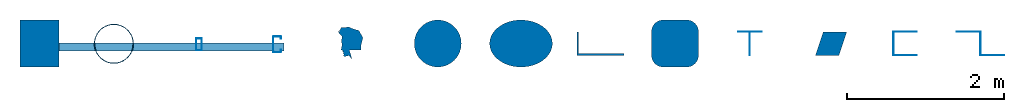
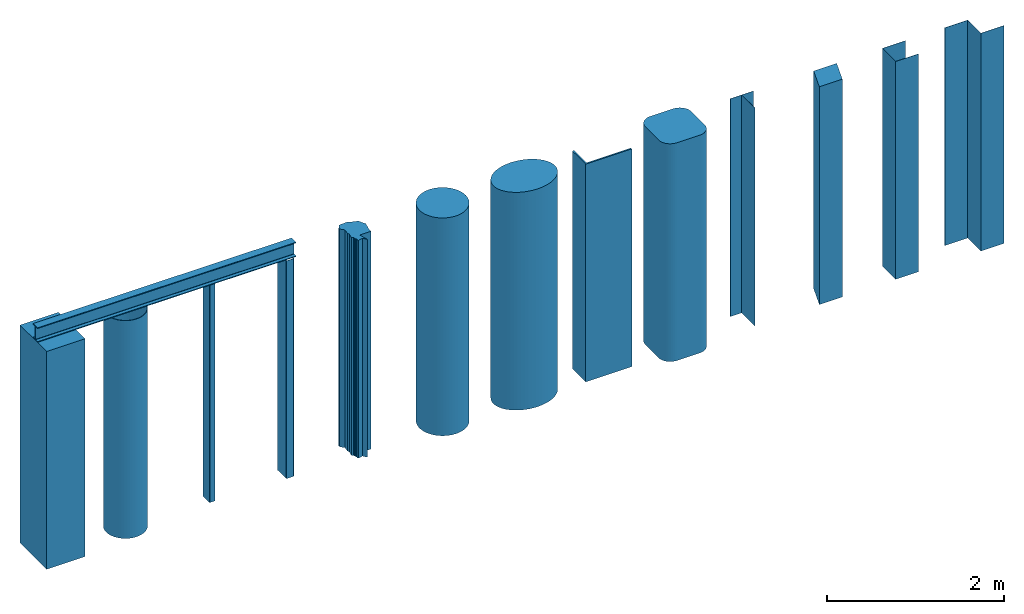
# One storey: 13 columns, 1 beam.
"""IFC4 building model written with IfcOpenShell, lengths in millimetres."""

from ifc_helpers import new_model, entity, si_unit, converted_unit, frame, origin_with_axes, origin_2d_with_axis, place, context, subcontext, project, spatial, line, indexed_curve, rectangle, rounded_rectangle, hollow_rectangle, circle, hollow_circle, ellipse, i_section, l_section, t_section, u_section, c_section, z_section, outline, extrude, material, material_profile, profile_set, profile_usage, type_object, element, save


model = new_model("IFC4")

# Units and contexts
model_context = context("Model", 3, precision=1e-05, world=origin_with_axes())
plan_context = context("Plan", 2, precision=1e-05, world=origin_2d_with_axis())
body_context = subcontext(model_context, "Body", "Model", "MODEL_VIEW")
ifc_project = project(units=[si_unit("LENGTHUNIT", "METRE", prefix="MILLI"), converted_unit("PLANEANGLEUNIT", "degree", entity("IfcReal", 0.0174532925199433), si_unit("PLANEANGLEUNIT", "RADIAN"), dimensions=[0, 0, 0, 0, 0, 0, 0]), si_unit("AREAUNIT", "SQUARE_METRE"), si_unit("VOLUMEUNIT", "CUBIC_METRE")], contexts=[model_context, plan_context])

# Site, building, storey
site_placement = place(None, origin_with_axes())
site = spatial("IfcSite", under=ifc_project, at=site_placement)
building_placement = place(site_placement, origin_with_axes())
building = spatial("IfcBuilding", under=site, at=building_placement, Name="Building")
storey_placement = place(building_placement, origin_with_axes())
storey = spatial("IfcBuildingStorey", under=building, at=storey_placement, Name="Storey")

# Columns
ifc_material = material()
ifc_material_profile_1 = material_profile(ifc_material, rectangle(XDim=500.0, YDim=600.0))
ifc_profile_set_1 = profile_set([ifc_material_profile_1])
ifc_profile_usage_1 = profile_usage(ifc_profile_set_1, cardinal=5)
column_type_1 = type_object("IfcColumnType", Name="C1", PredefinedType="NOTDEFINED", material=ifc_profile_set_1)
column_1_placement = place(storey_placement, frame((995.811939239502, 0.0, 0.0), z_axis=(0.0, 0.0, 1.0), x_axis=(1.0, 0.0, 0.0)))
element("IfcColumn", 1, at=column_1_placement, inside=storey, type_object=column_type_1, material=ifc_profile_usage_1, Name="Column", context=body_context, shape_type="SweptSolid", body=[
    extrude(rectangle(XDim=500.0, YDim=600.0), origin_with_axes(), (0.0, 0.0, 1.0), 3000.0),
])
ifc_material_profile_2 = material_profile(ifc_material, hollow_circle(Radius=250.0, WallThickness=5.0))
ifc_profile_set_2 = profile_set([ifc_material_profile_2])
ifc_profile_usage_2 = profile_usage(ifc_profile_set_2, cardinal=5)
column_type_2 = type_object("IfcColumnType", Name="C2", PredefinedType="NOTDEFINED", material=ifc_profile_set_2)
column_2_placement = place(storey_placement, frame((1943.9605474472, -3.62757779657841, 0.0), z_axis=(0.0, 0.0, 1.0), x_axis=(1.0, 0.0, 0.0)))
element("IfcColumn", 2, at=column_2_placement, inside=storey, type_object=column_type_2, material=ifc_profile_usage_2, Name="Column", context=body_context, shape_type="SweptSolid", body=[
    extrude(hollow_circle(Radius=250.0, WallThickness=5.0), origin_with_axes(), (0.0, 0.0, 1.0), 3000.0),
])
ifc_material_profile_3 = material_profile(ifc_material, hollow_rectangle(XDim=75.0, YDim=150.0, WallThickness=2.0, InnerFilletRadius=5.0, OuterFilletRadius=5.0))
ifc_profile_set_3 = profile_set([ifc_material_profile_3])
ifc_profile_usage_3 = profile_usage(ifc_profile_set_3, cardinal=5)
column_type_3 = type_object("IfcColumnType", Name="C3", PredefinedType="NOTDEFINED", material=ifc_profile_set_3)
column_3_placement = place(storey_placement, frame((3030.70211410522, -10.1517168805003, 0.0), z_axis=(0.0, 0.0, 1.0), x_axis=(1.0, 0.0, 0.0)))
element("IfcColumn", 3, at=column_3_placement, inside=storey, type_object=column_type_3, material=ifc_profile_usage_3, Name="Column", context=body_context, shape_type="SweptSolid", body=[
    extrude(hollow_rectangle(XDim=75.0, YDim=150.0, WallThickness=2.0, InnerFilletRadius=5.0, OuterFilletRadius=5.0), origin_with_axes(), (0.0, 0.0, 1.0), 3000.0),
])
ifc_material_profile_4 = material_profile(ifc_material, c_section(Depth=200.0, Width=100.0, WallThickness=1.5, Girth=30.0, InternalFilletRadius=5.0))
ifc_profile_set_4 = profile_set([ifc_material_profile_4])
ifc_profile_usage_4 = profile_usage(ifc_profile_set_4)
column_type_4 = type_object("IfcColumnType", Name="C4", PredefinedType="COLUMN", material=ifc_profile_set_4)
column_4_placement = place(storey_placement, frame((4028.40518951416, -10.1517168805003, 0.0), z_axis=(0.0, 0.0, 1.0), x_axis=(1.0, 0.0, 0.0)))
element("IfcColumn", 4, at=column_4_placement, inside=storey, type_object=column_type_4, material=ifc_profile_usage_4, Name="Column", context=body_context, shape_type="SweptSolid", body=[
    extrude(c_section(Depth=200.0, Width=100.0, WallThickness=1.5, Girth=30.0, InternalFilletRadius=5.0), origin_with_axes(), (0.0, 0.0, 1.0), 2999.9995231628),
])
ifc_material_profile_5 = material_profile(ifc_material, outline(indexed_curve([(-33.1290327012539, 5.71074709296227), (-22.5666034966707, -7.34817422926426), (35.0778363645077, 5.80643629655242), (73.9730075001717, -41.8017953634262), (61.4613816142082, 5.76200522482395), (40.2192026376724, 77.0668014883995), (187.038466334343, 78.6670297384262), (212.925970554352, 233.125388622284), (164.677247405052, 323.837637901306), (60.691524296999, 356.747835874557), (39.8134775459766, 370.091468095779), (-61.8956759572029, 363.280177116394), (-87.8583937883377, 322.536736726761), (-82.3076441884041, 278.543472290039), (-53.3980876207352, 249.455615878105), (-61.3004565238953, 175.858914852142), (-50.9787499904633, 149.412617087364), (-66.1437660455704, 78.9279416203499), (-41.6950061917305, 68.9443051815033), (-46.0562668740749, 52.478414028883), (-34.5521420240402, 47.1264719963074), (-40.3240844607353, 32.9264923930168), (-27.3645464330912, 27.2670034319162), (-83.9774683117867, 300.942122936249), (-95.3071340918541, 302.448153495789), (-97.1801355481148, 319.48447227478), (186.777621507645, 122.284486889839)], segments=[line(25, 26), line(26, 24), line(24, 13), line(13, 12), line(12, 11), line(11, 10), line(10, 9), line(9, 8), line(8, 27), line(27, 7), line(7, 6), line(6, 5), line(5, 4), line(4, 3), line(3, 2), line(2, 1), line(1, 23), line(23, 22), line(22, 21), line(21, 20), line(20, 19), line(19, 18), line(18, 17), line(17, 16), line(16, 15), line(15, 14), line(14, 25)], self_intersect=False)))
ifc_profile_set_5 = profile_set([ifc_material_profile_5])
ifc_profile_usage_5 = profile_usage(ifc_profile_set_5)
column_type_5 = type_object("IfcColumnType", Name="C5", PredefinedType="COLUMN", material=ifc_profile_set_5)
column_5_placement = place(storey_placement, frame((4909.0633392334, -160.008922219276, 0.000238418579101562), z_axis=(0.0, 0.0, 1.0), x_axis=(1.0, 0.0, 0.0)))
element("IfcColumn", 5, at=column_5_placement, inside=storey, type_object=column_type_5, material=ifc_profile_usage_5, Name="Column", context=body_context, shape_type="SweptSolid", body=[
    extrude(outline(indexed_curve([(-33.1290327012539, 5.71074709296227), (-22.5666034966707, -7.34817422926426), (35.0778363645077, 5.80643629655242), (73.9730075001717, -41.8017953634262), (61.4613816142082, 5.76200522482395), (40.2192026376724, 77.0668014883995), (187.038466334343, 78.6670297384262), (212.925970554352, 233.125388622284), (164.677247405052, 323.837637901306), (60.691524296999, 356.747835874557), (39.8134775459766, 370.091468095779), (-61.8956759572029, 363.280177116394), (-87.8583937883377, 322.536736726761), (-82.3076441884041, 278.543472290039), (-53.3980876207352, 249.455615878105), (-61.3004565238953, 175.858914852142), (-50.9787499904633, 149.412617087364), (-66.1437660455704, 78.9279416203499), (-41.6950061917305, 68.9443051815033), (-46.0562668740749, 52.478414028883), (-34.5521420240402, 47.1264719963074), (-40.3240844607353, 32.9264923930168), (-27.3645464330912, 27.2670034319162), (-83.9774683117867, 300.942122936249), (-95.3071340918541, 302.448153495789), (-97.1801355481148, 319.48447227478), (186.777621507645, 122.284486889839)], segments=[line(25, 26), line(26, 24), line(24, 13), line(13, 12), line(12, 11), line(11, 10), line(10, 9), line(9, 8), line(8, 27), line(27, 7), line(7, 6), line(6, 5), line(5, 4), line(4, 3), line(3, 2), line(2, 1), line(1, 23), line(23, 22), line(22, 21), line(21, 20), line(20, 19), line(19, 18), line(18, 17), line(17, 16), line(16, 15), line(15, 14), line(14, 25)], self_intersect=False)), origin_with_axes(), (0.0, 0.0, 1.0), 3000.0),
])
ifc_material_profile_6 = material_profile(ifc_material, circle(Radius=300.0))
ifc_profile_set_6 = profile_set([ifc_material_profile_6])
ifc_profile_usage_6 = profile_usage(ifc_profile_set_6)
column_type_6 = type_object("IfcColumnType", Name="C6", PredefinedType="COLUMN", material=ifc_profile_set_6)
column_6_placement = place(storey_placement, frame((6077.8112411499, 0.0, 0.0), z_axis=(0.0, 0.0, 1.0), x_axis=(1.0, 0.0, 0.0)))
element("IfcColumn", 6, at=column_6_placement, inside=storey, type_object=column_type_6, material=ifc_profile_usage_6, Name="Column", context=body_context, shape_type="SweptSolid", body=[
    extrude(circle(Radius=300.0), origin_with_axes(), (0.0, 0.0, 1.0), 3000.0),
])
ifc_material_profile_7 = material_profile(ifc_material, ellipse(SemiAxis1=400.0, SemiAxis2=300.0))
ifc_profile_set_7 = profile_set([ifc_material_profile_7])
ifc_profile_usage_7 = profile_usage(ifc_profile_set_7)
column_type_7 = type_object("IfcColumnType", Name="C7", PredefinedType="COLUMN", material=ifc_profile_set_7)
column_7_placement = place(storey_placement, frame((7140.21635055542, 0.0, 0.0), z_axis=(0.0, 0.0, 1.0), x_axis=(1.0, 0.0, 0.0)))
element("IfcColumn", 7, at=column_7_placement, inside=storey, type_object=column_type_7, material=ifc_profile_usage_7, Name="Column", context=body_context, shape_type="SweptSolid", body=[
    extrude(ellipse(SemiAxis1=400.0, SemiAxis2=300.0), origin_with_axes(), (0.0, 0.0, 1.0), 2999.99984105428),
])
ifc_material_profile_8 = material_profile(ifc_material, l_section(Depth=300.0, Width=600.0, Thickness=20.0, FilletRadius=0.0, EdgeRadius=0.0, LegSlope=0.0))
ifc_profile_set_8 = profile_set([ifc_material_profile_8])
ifc_profile_usage_8 = profile_usage(ifc_profile_set_8)
column_type_8 = type_object("IfcColumnType", Name="C8", PredefinedType="COLUMN", material=ifc_profile_set_8)
column_8_placement = place(storey_placement, frame((8155.517578125, 0.0, 0.0), z_axis=(0.0, 0.0, 1.0), x_axis=(1.0, 0.0, 0.0)))
element("IfcColumn", 8, at=column_8_placement, inside=storey, type_object=column_type_8, material=ifc_profile_usage_8, Name="Column", context=body_context, shape_type="SweptSolid", body=[
    extrude(l_section(Depth=300.0, Width=600.0, Thickness=20.0, FilletRadius=0.0, EdgeRadius=0.0, LegSlope=0.0), origin_with_axes(), (0.0, 0.0, 1.0), 3000.0),
])
ifc_material_profile_9 = material_profile(ifc_material, rounded_rectangle(XDim=600.0, YDim=600.0, RoundingRadius=150.0))
ifc_profile_set_9 = profile_set([ifc_material_profile_9])
ifc_profile_usage_9 = profile_usage(ifc_profile_set_9)
column_type_9 = type_object("IfcColumnType", Name="C9", PredefinedType="COLUMN", material=ifc_profile_set_9)
column_9_placement = place(storey_placement, frame((9105.29613494873, 0.0, 0.0), z_axis=(0.0, 0.0, 1.0), x_axis=(1.0, 0.0, 0.0)))
element("IfcColumn", 9, at=column_9_placement, inside=storey, type_object=column_type_9, material=ifc_profile_usage_9, Name="Column", context=body_context, shape_type="SweptSolid", body=[
    extrude(rounded_rectangle(XDim=600.0, YDim=600.0, RoundingRadius=150.0), origin_with_axes(), (0.0, 0.0, 1.0), 3000.0),
])
ifc_material_profile_10 = material_profile(ifc_material, t_section(Depth=300.0, FlangeWidth=300.0, WebThickness=3.0, FlangeThickness=3.0))
ifc_profile_set_10 = profile_set([ifc_material_profile_10])
ifc_profile_usage_10 = profile_usage(ifc_profile_set_10)
column_type_10 = type_object("IfcColumnType", Name="C10", PredefinedType="COLUMN", material=ifc_profile_set_10)
column_10_placement = place(storey_placement, frame((10060.4991912842, 0.0, 0.0), z_axis=(0.0, 0.0, 1.0), x_axis=(1.0, 0.0, 0.0)))
element("IfcColumn", 10, at=column_10_placement, inside=storey, type_object=column_type_10, material=ifc_profile_usage_10, Name="Column", context=body_context, shape_type="SweptSolid", body=[
    extrude(t_section(Depth=300.0, FlangeWidth=300.0, WebThickness=3.0, FlangeThickness=3.0), origin_with_axes(), (0.0, 0.0, 1.0), 3000.0),
])
ifc_material_profile_11 = material_profile(ifc_material, entity("IfcTrapeziumProfileDef", "AREA", None, None, 300.0, 300.0, 300.0, 100.0))
ifc_profile_set_11 = profile_set([ifc_material_profile_11])
ifc_profile_usage_11 = profile_usage(ifc_profile_set_11)
column_type_11 = type_object("IfcColumnType", Name="C11", PredefinedType="COLUMN", material=ifc_profile_set_11)
column_11_placement = place(storey_placement, frame((11098.6528396606, 0.0, 0.0), z_axis=(0.0, 0.0, 1.0), x_axis=(1.0, 0.0, 0.0)))
element("IfcColumn", 11, at=column_11_placement, inside=storey, type_object=column_type_11, material=ifc_profile_usage_11, Name="Column", context=body_context, shape_type="SweptSolid", body=[
    extrude(entity("IfcTrapeziumProfileDef", "AREA", None, None, 300.0, 300.0, 300.0, 100.0), origin_with_axes(), (0.0, 0.0, 1.0), 3000.0),
])
ifc_material_profile_12 = material_profile(ifc_material, u_section(Depth=300.0, FlangeWidth=300.0, WebThickness=3.0, FlangeThickness=3.0))
ifc_profile_set_12 = profile_set([ifc_material_profile_12])
ifc_profile_usage_12 = profile_usage(ifc_profile_set_12)
column_type_12 = type_object("IfcColumnType", Name="C12", PredefinedType="COLUMN", material=ifc_profile_set_12)
column_12_placement = place(storey_placement, frame((12043.3034896851, 0.0, 0.0), z_axis=(0.0, 0.0, 1.0), x_axis=(1.0, 0.0, 0.0)))
element("IfcColumn", 12, at=column_12_placement, inside=storey, type_object=column_type_12, material=ifc_profile_usage_12, Name="Column", context=body_context, shape_type="SweptSolid", body=[
    extrude(u_section(Depth=300.0, FlangeWidth=300.0, WebThickness=3.0, FlangeThickness=3.0), origin_with_axes(), (0.0, 0.0, 1.0), 3000.0),
])
ifc_material_profile_13 = material_profile(ifc_material, z_section(Depth=300.0, FlangeWidth=300.0, WebThickness=3.0, FlangeThickness=3.0))
ifc_profile_set_13 = profile_set([ifc_material_profile_13])
ifc_profile_usage_13 = profile_usage(ifc_profile_set_13)
column_type_13 = type_object("IfcColumnType", Name="C13", PredefinedType="COLUMN", material=ifc_profile_set_13)
column_13_placement = place(storey_placement, frame((13004.5824050903, 0.0, 0.0), z_axis=(0.0, 0.0, 1.0), x_axis=(1.0, 0.0, 0.0)))
element("IfcColumn", 13, at=column_13_placement, inside=storey, type_object=column_type_13, material=ifc_profile_usage_13, Name="Column", context=body_context, shape_type="SweptSolid", body=[
    extrude(z_section(Depth=300.0, FlangeWidth=300.0, WebThickness=3.0, FlangeThickness=3.0), origin_with_axes(), (0.0, 0.0, 1.0), 3000.0),
])

# Beam
ifc_material_profile_14 = material_profile(ifc_material, i_section(OverallWidth=100.0, OverallDepth=200.0, WebThickness=5.0, FlangeThickness=10.0, FilletRadius=5.0))
ifc_profile_set_14 = profile_set([ifc_material_profile_14])
ifc_profile_usage_14 = profile_usage(ifc_profile_set_14, cardinal=5)
beam_type = type_object("IfcBeamType", Name="B1", PredefinedType="NOTDEFINED", material=ifc_profile_set_14)
beam_placement = place(storey_placement, frame((745.811939239502, -44.3866103887558, 3099.99990463257), z_axis=(0.999999999999973, 1.62920699153797e-07, -1.62920684942942e-07), x_axis=(-1.62920684942943e-07, 0.99999999999998, 1.19209275339924e-07)))
element("IfcBeam", 14, at=beam_placement, inside=storey, type_object=beam_type, material=ifc_profile_usage_14, Name="Beam", context=body_context, shape_type="SweptSolid", body=[
    extrude(i_section(OverallWidth=100.0, OverallDepth=200.0, WebThickness=5.0, FlangeThickness=10.0, FilletRadius=5.0), origin_with_axes(), (0.0, 0.0, 1.0), 3369.68159675598),
])

save(model, "model.ifc")
